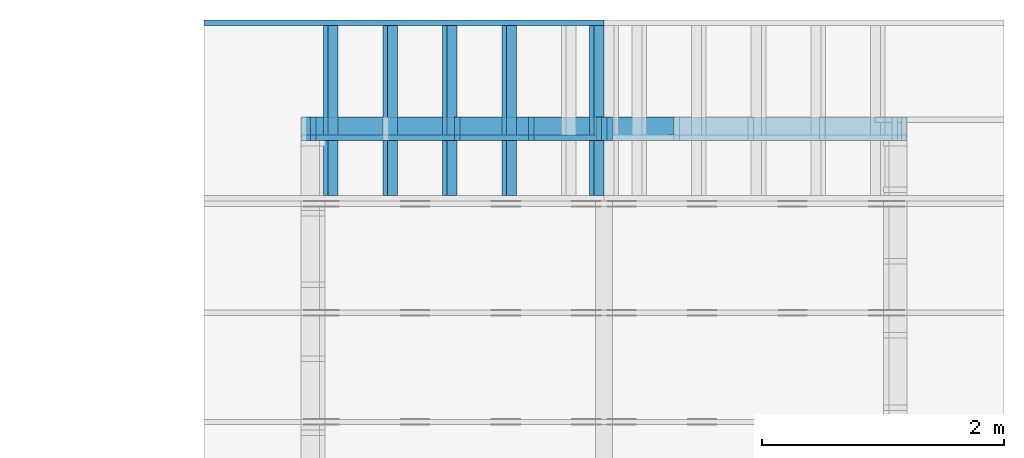
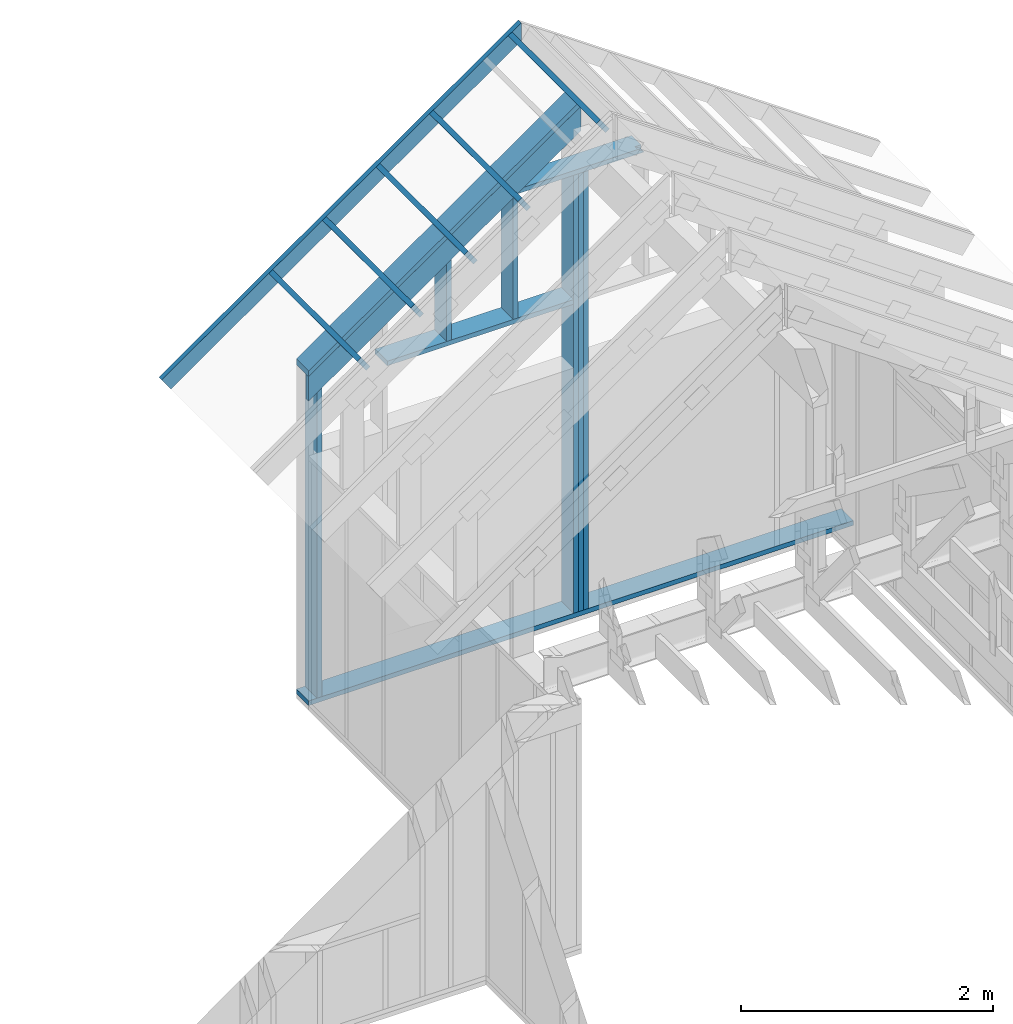
# One storey, part 34 of 70: 17 members, 2 elements without a shape of their own.
"""IFC2X3 building model written with IfcOpenShell, lengths in millimetres."""

from ifc_helpers import new_model, si_unit, frame, origin, origin_with_axes, origin_2d, place, context, project, spatial, faceted_brep, element, aggregate, save


model = new_model("IFC2X3")

# Units and contexts
model_context = context("Model", 3, precision=1e-05, world=origin())
plan_context = context("Plan", 2, precision=1e-05, world=origin_2d())
ifc_project = project(units=[si_unit("LENGTHUNIT", "METRE", prefix="MILLI"), si_unit("AREAUNIT", "SQUARE_METRE"), si_unit("VOLUMEUNIT", "CUBIC_METRE"), si_unit("SOLIDANGLEUNIT", "STERADIAN"), si_unit("PLANEANGLEUNIT", "RADIAN"), si_unit("MASSUNIT", "GRAM"), si_unit("TIMEUNIT", "SECOND"), si_unit("THERMODYNAMICTEMPERATUREUNIT", "DEGREE_CELSIUS"), si_unit("LUMINOUSINTENSITYUNIT", "LUMEN")], contexts=[model_context, plan_context])

# Site, building, storey
site_placement = place(None, origin_with_axes())
site = spatial("IfcSite", under=ifc_project, at=site_placement, CompositionType="ELEMENT")
building_placement = place(site_placement, origin_with_axes())
building = spatial("IfcBuilding", under=site, at=building_placement, Name="Layout 1", CompositionType="ELEMENT")
storey_placement = place(building_placement, origin_with_axes())
storey = spatial("IfcBuildingStorey", under=building, at=storey_placement, Name="Storey 1", CompositionType="ELEMENT", Elevation=0.0)

# Assembly, members
assembly_1_placement = place(storey_placement, frame((12000.0, 12000.0, -2470.0), z_axis=(1.2246063538223773e-16, 1.0, 6.123031769111886e-17), x_axis=(-1.0, 1.2246063538223773e-16, 0.0)))
assembly_1 = element("IfcElementAssembly", 1, at=assembly_1_placement, inside=storey, Name="VE6", AssemblyPlace="FACTORY", PredefinedType="NOTDEFINED")
member_1_placement = place(assembly_1_placement, frame((2474.1890603637416, 5006.644688160831, -195.0), z_axis=(0.0, 0.0, 1.0), x_axis=(0.819152044288991, -0.5735764363510472, 0.0)))
member_1 = element("IfcMember", 2, at=member_1_placement, Name="P9", context=model_context, shape_type="Brep", body=[
    faceted_brep([(3051.936471903848, 45.000000000511136, 195.0), (0.0, 45.000000000511136, 195.0), (31.50933921872638, 1.8226273823529482e-09, 195.0), (3083.4458111236427, 1.8226273823529482e-09, 195.0), (0.0, 45.000000000511136, 0.0), (3051.936471903848, 45.000000000511136, 3.7374207949557014e-13), (3083.4458111236427, 1.8226273823529482e-09, 3.776007331969007e-13), (31.50933921872638, 1.8226273823529482e-09, 3.858653701199695e-15), (31.50933921872638, 1.8226327114234664e-09, -1.9721522630525295e-31), (31.509339218726396, 1.822639816850824e-09, 195.0), (0.0, 45.00000000080673, 195.0), (-1.0658141036401503e-14, 45.00000000080672, 7.888609052210118e-31), (3083.4458111236427, 5.056527393017496e-13, -3.096127786882771e-29), (3083.4458111236427, 5.175926512515177e-13, 195.0), (31.50933921872638, 1.8226444894657068e-09, 195.0), (31.50933921872638, 1.822632549553757e-09, -3.1638934709611835e-31), (3051.936471903848, 45.00000000051091, 5.605193857299268e-45), (3051.936471903848, 45.00000000051091, 195.0), (3083.4458111236427, -2.2737367544323206e-13, 195.0), (3083.4458111236427, -2.2737367544323206e-13, 5.605193857299268e-45), (0.0, 45.00000000080672, 0.0), (-8.077935669463161e-28, 45.00000000080671, 195.0), (3051.936471903848, 45.00000000051174, 195.0), (3051.936471903848, 45.00000000051175, 3.747089299799806e-29)], [[[0, 1, 2, 3]], [[4, 5, 6, 7]], [[8, 9, 10, 11]], [[12, 13, 14, 15]], [[16, 17, 18, 19]], [[20, 21, 22, 23]]]),
])
member_2_placement = place(assembly_1_placement, frame((4999.999999999999, 90.0, -195.0), z_axis=(0.0, 0.0, 1.0), x_axis=(-1.0, 1.2246063538223773e-16, 0.0)))
member_2 = element("IfcMember", 3, at=member_2_placement, Name="P5", context=model_context, shape_type="Brep", body=[
    faceted_brep([(4999.999999999999, 45.00000000000061, 195.0), (0.0, 45.00000000000061, 195.0), (0.0, 0.0, 195.0), (4999.999999999999, 0.0, 195.0), (0.0, 45.00000000000061, 0.0), (4999.999999999999, 45.00000000000061, 6.123031769111885e-13), (4999.999999999999, 0.0, 6.123031769111885e-13), (0.0, 0.0, 0.0), (0.0, 0.0, 0.0), (1.1939911949768178e-14, -1.462169203776584e-30, 195.0), (1.7450640541968876e-14, 45.0, 195.0), (5.510728592200698e-15, 45.0, -3.3742366240998092e-31), (4999.999999999999, -9.184547653667827e-13, 9.365308846991873e-29), (4999.999999999999, -9.065148534170146e-13, 195.0), (2.193253805664876e-30, 1.1939911949768178e-14, 195.0), (0.0, 0.0, 0.0), (4999.999999999999, 45.00000000000061, 0.0), (4999.999999999999, 45.00000000000061, 195.0), (4999.999999999999, 6.110667527536862e-13, 195.0), (4999.999999999999, 6.110667527536862e-13, 0.0), (0.0, 45.0, 0.0), (1.5777218104420236e-30, 44.999999999999986, 195.0), (4999.999999999999, 45.00000000000079, 195.0), (4999.999999999999, 45.0000000000008, 1.1832913578315177e-29)], [[[0, 1, 2, 3]], [[4, 5, 6, 7]], [[8, 9, 10, 11]], [[12, 13, 14, 15]], [[16, 17, 18, 19]], [[20, 21, 22, 23]]]),
])
member_3_placement = place(assembly_1_placement, frame((4922.4999999994125, 90.0, -195.00000000000003), z_axis=(0.0, 0.0, 1.0), x_axis=(6.123031769111886e-17, 1.0, 0.0)))
member_3 = element("IfcMember", 4, at=member_3_placement, Name="S4/", context=model_context, shape_type="Brep", body=[
    faceted_brep([(2995.777206757778, 45.00000000000978, 2.8421709430404083e-14), (2995.777206757778, 45.00000000000978, 45.00000000000003), (2964.267867538344, -2.2737367544323206e-13, 45.00000000000003), (2964.267867538344, -2.2737367544323206e-13, 2.8421709430404083e-14), (2995.7772067577775, 45.000000000010004, 45.0000000000004), (3233.828251566185, 45.000000000010004, 45.000000000000426), (3202.318912346716, 2.3646862246096134e-11, 45.00000000000042), (2964.26786753831, 2.3646862246096134e-11, 45.00000000000039), (4.547473508864641e-13, 45.000000000009095, 2.842170943040401e-14), (4.547473508864641e-13, 45.00000000000908, 195.00000000000003), (3233.828251566185, 45.00000000000888, 195.00000000000003), (3233.828251566185, 45.000000000008896, 45.00000000000003), (2995.7772067577775, 45.00000000000891, 45.00000000000003), (2995.7772067577775, 45.00000000000891, 2.8421709430403995e-14), (4.547473508864641e-13, 45.00000000002365, 2.8421709430404064e-14), (2995.7772067577775, 45.00000000002365, 3.952864896335868e-13), (2964.2678675383095, 2.3646862246096134e-11, 3.914278359322963e-13), (0.0, 2.3646862246096134e-11, 2.842170943040401e-14), (-5.038518148775102e-27, 2.3646862246096134e-11, 3.0851006694196666e-43), (1.193991194976314e-14, 2.3646862246096134e-11, 195.00000000000003), (4.570989582935258e-13, 45.00000000002365, 195.00000000000003), (4.4515904634375764e-13, 45.00000000002365, 5.870949332691174e-31), (3202.318912346716, 2.306138059733843e-11, 45.00000000000003), (3202.318912346716, 2.30705651449921e-11, 195.00000000000003), (2.1932538056648764e-30, 2.3658802158045902e-11, 195.00000000000003), (3.196719095986404e-46, 2.3646862246096134e-11, 2.8421709430404004e-14), (2964.26786753831, 2.3102353056343295e-11, 2.8421709430404045e-14), (2964.26786753831, 2.3105108420639396e-11, 45.00000000000003), (3233.828251566151, 45.0000000000332, 45.00000000000003), (3233.828251566151, 45.0000000000332, 195.00000000000003), (3202.318912346717, 2.319211489520967e-11, 195.00000000000003), (3202.318912346717, 2.319211489520967e-11, 45.00000000000003), (3233.828251566185, 45.000000000009095, 195.00000000000003), (4.547473508864641e-13, 45.000000000009095, 195.00000000000003), (0.0, 2.3646862246096134e-11, 195.00000000000003), (3202.318912346716, 2.3646862246096134e-11, 195.00000000000003)], [[[0, 1, 2, 3]], [[4, 5, 6, 7]], [[8, 9, 10, 11, 12, 13]], [[14, 15, 16, 17]], [[18, 19, 20, 21]], [[22, 23, 24, 25, 26, 27]], [[28, 29, 30, 31]], [[32, 33, 34, 35]]]),
])
member_4_placement = place(assembly_1_placement, frame((2567.499999999389, 90.0, -195.0), z_axis=(0.0, 0.0, 1.0), x_axis=(6.123031769111886e-17, 1.0, 0.0)))
member_4 = element("IfcMember", 5, at=member_4_placement, Name="S1", context=model_context, shape_type="Brep", body=[
    faceted_brep([(4249.700815737255, 45.000000000000455, 195.0), (0.0, 45.000000000000455, 195.0), (0.0, 0.0, 195.0), (4249.700815737255, 0.0, 195.0), (0.0, 45.000000000000455, 0.0), (4249.700815737255, 45.000000000000455, 5.204210620795982e-13), (4249.700815737255, 0.0, 5.204210620795982e-13), (0.0, 0.0, 0.0), (0.0, 0.0, 0.0), (1.1939911949768178e-14, -1.462169203776584e-30, 195.0), (1.7450640541968876e-14, 45.0, 195.0), (5.510728592200698e-15, 45.0, -3.3742366240998092e-31), (4249.700815737255, 1.8091831180479842e-11, -1.88905853583765e-28), (4249.700815737255, 1.810377109242961e-11, 195.0), (-5.083060682885383e-29, 1.1939911949768178e-14, 195.0), (0.0, 0.0, 0.0), (4249.700815737255, 45.000000000000455, 0.0), (4249.700815737255, 45.000000000000455, 195.0), (4249.700815737255, 1.5006662579253316e-11, 195.0), (4249.700815737255, 1.5006662579253316e-11, 0.0), (0.0, 45.0, 0.0), (1.5777218104420236e-30, 44.999999999999986, 195.0), (4249.700815737255, 45.000000000000675, 195.0), (4249.700815737255, 45.00000000000068, 1.3805065841367707e-29)], [[[0, 1, 2, 3]], [[4, 5, 6, 7]], [[8, 9, 10, 11]], [[12, 13, 14, 15]], [[16, 17, 18, 19]], [[20, 21, 22, 23]]]),
])
member_5_placement = place(assembly_1_placement, frame((2522.499999999389, 90.0, -195.0), z_axis=(0.0, 0.0, 1.0), x_axis=(6.123031769111886e-17, 1.0, 0.0)))
member_5 = element("IfcMember", 6, at=member_5_placement, Name="S1", context=model_context, shape_type="Brep", body=[
    faceted_brep([(4249.700815737255, 45.00000000001501, 195.0), (0.0, 45.00000000001501, 195.0), (0.0, 0.0, 195.0), (4249.700815737255, 0.0, 195.0), (0.0, 45.00000000001501, 0.0), (4249.700815737255, 45.00000000001501, 5.204210620795982e-13), (4249.700815737255, 0.0, 5.204210620795982e-13), (0.0, 0.0, 0.0), (0.0, 0.0, 0.0), (1.1939911949768178e-14, -1.462169203776584e-30, 195.0), (1.745064054197066e-14, 45.00000000001455, 195.0), (5.51072859220248e-15, 45.00000000001455, -3.3742366241009005e-31), (4249.700815737255, -7.806315931193973e-13, 7.564264521039784e-29), (4249.700815737255, -7.686916811696291e-13, 195.0), (2.193253805664876e-30, 1.1939911949768178e-14, 195.0), (0.0, 0.0, 0.0), (4249.700815737255, 45.00000000001501, 0.0), (4249.700815737255, 45.00000000001501, 195.0), (4249.700815737255, 4.547473508864641e-13, 195.0), (4249.700815737255, 4.547473508864641e-13, 0.0), (0.0, 45.00000000001455, 0.0), (1.5777218104420236e-30, 45.00000000001454, 195.0), (4249.700815737255, 45.00000000001523, 195.0), (4249.700815737255, 45.000000000015234, 1.3805065841367707e-29)], [[[0, 1, 2, 3]], [[4, 5, 6, 7]], [[8, 9, 10, 11]], [[12, 13, 14, 15]], [[16, 17, 18, 19]], [[20, 21, 22, 23]]]),
])
member_6_placement = place(assembly_1_placement, frame((2477.4999999993743, 89.99999999999999, -195.0), z_axis=(0.0, 0.0, 1.0), x_axis=(6.123031769111886e-17, 1.0, 0.0)))
member_6 = element("IfcMember", 7, at=member_6_placement, Name="S1", context=model_context, shape_type="Brep", body=[
    faceted_brep([(4249.700815737255, 45.000000000000455, 195.0), (0.0, 45.000000000000455, 195.0), (1.4210854715202004e-14, 0.0, 195.0), (4249.700815737255, 0.0, 195.0), (0.0, 45.000000000000455, 0.0), (4249.700815737255, 45.000000000000455, 5.204210620795982e-13), (4249.700815737255, 0.0, 5.204210620795982e-13), (1.4210854715202004e-14, 0.0, 1.7402702977483063e-30), (1.4210854715202002e-14, 0.0, 1.7516230804060213e-46), (2.6150766664970182e-14, -1.462169203776584e-30, 195.0), (3.166149525717088e-14, 45.0, 195.0), (1.97215833074027e-14, 45.0, -1.2075588112841339e-30), (4249.700815737255, -7.806315931193973e-13, 7.564264521039784e-29), (4249.700815737255, -7.686916811696291e-13, 195.0), (1.4210854715202007e-14, 1.1939911949768174e-14, 195.0), (1.4210854715202004e-14, -4.131065092035501e-30, 2.5294642798802494e-46), (4249.700815737255, 45.000000000000455, 0.0), (4249.700815737255, 45.000000000000455, 195.0), (4249.700815737255, 4.547473508864641e-13, 195.0), (4249.700815737255, 4.547473508864641e-13, 0.0), (0.0, 45.0, 0.0), (1.5777218104420236e-30, 44.999999999999986, 195.0), (4249.700815737255, 45.000000000000675, 195.0), (4249.700815737255, 45.00000000000068, 1.3805065841367707e-29)], [[[0, 1, 2, 3]], [[4, 5, 6, 7]], [[8, 9, 10, 11]], [[12, 13, 14, 15]], [[16, 17, 18, 19]], [[20, 21, 22, 23]]]),
])
member_7_placement = place(assembly_1_placement, frame((3687.5000000011987, 4157.075222035528, -195.0), z_axis=(0.0, 0.0, 1.0), x_axis=(-1.836909530733566e-16, -1.0, 0.0)))
member_7 = element("IfcMember", 8, at=member_7_placement, Name="S29/", context=model_context, shape_type="Brep", body=[
    faceted_brep([(31.509339219475805, 45.00000000002365, 45.00000000000001), (269.56038402787544, 45.00000000002365, 45.000000000000036), (238.05104480840146, 2.3646862246096134e-11, 45.00000000000003), (0.0, 2.3646862246096134e-11, 45.0), (238.05104480843508, -1.4210854715202004e-14, 1.5777218104420236e-30), (238.05104480843508, -1.4210854715202004e-14, 45.0), (269.56038402787544, 45.00000000002001, 45.0), (269.56038402787544, 45.00000000002001, 1.5777218104420236e-30), (3.274269947936954e-11, 9.08871366138303e-13, 45.0), (3.2750223020355916e-11, 9.036033260256165e-13, 195.0), (31.509339219475805, 45.000000000023654, 195.0), (31.509339219475798, 45.00000000002366, 45.0), (1022.0752220355334, 2.3459116274447763e-11, 3.9340070253230344e-29), (1022.0752220355334, 2.347105618639753e-11, 195.0), (2.193253805664876e-30, 2.3658802158045902e-11, 195.0), (5.061354936149714e-31, 2.3649617610392235e-11, 45.0), (238.05104480840146, 2.360588978709127e-11, 45.0), (238.05104480840146, 2.360313442279517e-11, 2.677468512659129e-30), (31.509339219475805, 45.00000000002, 45.0), (31.509339219475805, 45.000000000019995, 195.0), (1022.0752220355325, 45.00000000001994, 195.0), (1022.0752220355325, 45.000000000019945, -3.194886666145098e-29), (269.56038402787544, 45.000000000019995, -1.1832913578315177e-30), (269.56038402787544, 45.00000000001999, 45.0), (1022.0752220355334, 45.00000000000955, 2.842170943040407e-14), (1022.0752220355334, 45.00000000000955, 195.0), (1022.0752220355334, 2.4101609596982598e-11, 195.0), (1022.0752220355334, 2.4101609596982598e-11, 0.0), (1022.0752220355325, 45.00000000000955, 195.0), (31.509339219475805, 45.00000000000955, 195.0), (0.0, 2.3646862246096134e-11, 195.0), (1022.0752220355334, 2.3646862246096134e-11, 195.0), (269.56038402787544, 45.00000000002001, 3.3010535901933635e-14), (1022.0752220355325, 45.00000000002001, 1.25163981098913e-13), (1022.0752220355334, 2.4101609596982598e-11, 1.2516398109891314e-13), (238.05104480840146, 2.4101609596982598e-11, 2.915188220064239e-14)], [[[0, 1, 2, 3]], [[4, 5, 6, 7]], [[8, 9, 10, 11]], [[12, 13, 14, 15, 16, 17]], [[18, 19, 20, 21, 22, 23]], [[24, 25, 26, 27]], [[28, 29, 30, 31]], [[32, 33, 34, 35]]]),
])
member_8_placement = place(assembly_1_placement, frame((4277.499999999389, 3135.0, -195.0), z_axis=(0.0, 0.0, 1.0), x_axis=(-1.0, 1.2246063538223773e-16, 0.0)))
member_8 = element("IfcMember", 9, at=member_8_placement, Name="S18", context=model_context, shape_type="Brep", body=[
    faceted_brep([(1710.000000000011, 45.0, 195.0), (0.0, 45.0, 195.0), (0.0, 0.0, 195.0), (1710.000000000011, 0.0, 195.0), (0.0, 45.0, 0.0), (1710.000000000011, 45.0, 2.0940768650362785e-13), (1710.000000000011, 0.0, 2.0940768650362785e-13), (0.0, 0.0, 0.0), (0.0, 0.0, 0.0), (1.1939911949768178e-14, -1.462169203776584e-30, 195.0), (1.745064054197066e-14, 45.00000000001455, 195.0), (5.51072859220248e-15, 45.00000000001455, -3.3742366241009005e-31), (1710.000000000011, 1.3354954349429573e-11, 7.329029488117048e-29), (1710.000000000011, 1.3366894261379341e-11, 195.0), (-9.32496953364688e-29, 1.1939911949768178e-14, 195.0), (0.0, 0.0, 0.0), (1710.000000000011, 45.0, 0.0), (1710.000000000011, 45.0, 195.0), (1710.000000000011, 1.4551915228366852e-11, 195.0), (1710.000000000011, 1.4551915228366852e-11, 0.0), (0.0, 45.00000000001455, 0.0), (-1.0097419586828951e-28, 45.00000000001454, 195.0), (1710.000000000011, 45.00000000000001, 195.0), (1710.000000000011, 45.00000000000002, 1.1832913578315177e-30)], [[[0, 1, 2, 3]], [[4, 5, 6, 7]], [[8, 9, 10, 11]], [[12, 13, 14, 15]], [[16, 17, 18, 19]], [[20, 21, 22, 23]]]),
])
member_9_placement = place(assembly_1_placement, frame((3122.4999999994034, 3134.9999999999986, -195.0), z_axis=(0.0, 0.0, 1.0), x_axis=(6.123031769111886e-17, 1.0, 0.0)))
member_9 = element("IfcMember", 10, at=member_9_placement, Name="S19", context=model_context, shape_type="Brep", body=[
    faceted_brep([(1211.150775538174, 45.00000000187583, -1.262177448353619e-29), (1211.150775538174, 45.00000000187583, 45.0), (1179.6414363187228, 1.8417267710901797e-09, 45.0), (1179.6414363187228, 1.8417267710901797e-09, 0.0), (1211.150775538174, 45.00000000187583, 45.00000000000015), (1449.201820346841, 45.00000000187583, 45.00000000000018), (1417.6924811273652, 1.8649188859853894e-09, 45.00000000000017), (1179.641436318689, 1.8649188859853894e-09, 45.00000000000014), (2.800456213534592e-29, 45.00000000224145, 2.800456213534592e-29), (2.7273477533457627e-29, 45.000000002241435, 195.0), (1449.201820346841, 45.00000000224135, 195.0), (1449.201820346841, 45.00000000224136, 45.0), (1211.150775538174, 45.00000000224137, 45.0), (1211.150775538174, 45.00000000224138, -4.733165431326071e-30), (0.0, 45.00000000001455, 0.0), (1211.150775538174, 45.00000000001455, 1.4831829351609478e-13), (1179.641436318689, 1.865373633336276e-09, 1.4445963981480218e-13), (1.3642420526593924e-12, 1.865373633336276e-09, 1.670659485838374e-28), (1.3642420526593924e-12, 0.0, 0.0), (1.3761819646091605e-12, 3.5910008311095063e-28, 195.0), (2.2779711059732005e-14, 45.00000000001455, 195.0), (1.0839799109963827e-14, 45.00000000001455, -6.637243432109955e-31), (1417.6924811273652, 1.8646612240666624e-09, 45.0), (1417.6924811273652, 1.864670408614316e-09, 195.0), (1.3642420526593924e-12, 1.864930825897339e-09, 195.0), (1.3642420526593924e-12, 1.8649188859853894e-09, -2.78443247639729e-29), (1179.641436318689, 1.864702196525667e-09, 1.3267964459105144e-29), (1179.641436318689, 1.8647049518899633e-09, 45.0), (1449.2018203468665, 45.00000000222337, 45.0), (1449.2018203468665, 45.00000000222337, 195.0), (1417.6924811273652, 2.2414496925193816e-09, 195.0), (1417.6924811273652, 2.2414496925193816e-09, 45.0), (1449.201820346841, 45.00000000224145, 195.0), (0.0, 45.00000000224145, 195.0), (1.3642420526593924e-12, 0.0, 195.0), (1417.6924811273652, 0.0, 195.0)], [[[0, 1, 2, 3]], [[4, 5, 6, 7]], [[8, 9, 10, 11, 12, 13]], [[14, 15, 16, 17]], [[18, 19, 20, 21]], [[22, 23, 24, 25, 26, 27]], [[28, 29, 30, 31]], [[32, 33, 34, 35]]]),
])
member_10_placement = place(assembly_1_placement, frame((1922.500000000001, 4339.700815717399, -195.0), z_axis=(0.0, 0.0, 1.0), x_axis=(1.0, 2.362323900716526e-15, 0.0)))
member_10 = element("IfcMember", 11, at=member_10_placement, Name="S27", context=model_context, shape_type="Brep", body=[
    faceted_brep([(1099.9448369288095, 45.000000018900266, 0.0), (1099.9448369288095, 45.000000018900266, 45.0), (1154.9999999962727, 6.44995982164528, 45.0), (1154.9999999962727, 6.44995982164528, 0.0), (2.2737367544323206e-13, 45.00000001890021, 45.0), (55.055163047768474, 45.00000001890021, 45.00000000000001), (0.0, 6.449959821647099, 45.0), (1099.9448369288095, 45.00000001890021, 45.000000000000135), (1154.999999996274, 45.00000001890021, 45.00000000000014), (1154.999999996274, 6.449959821647099, 45.00000000000014), (2.2737367544323206e-13, 45.000000019846084, 45.0), (2.2737367544323206e-13, 45.00000001984607, 195.0), (1154.999999996274, 45.000000019846, 195.0), (1154.999999996274, 45.00000001984601, 45.0), (1099.9448369288095, 45.00000001984601, 45.0), (1099.9448369288095, 45.00000001984602, -3.944304526105059e-30), (55.055163047768474, 45.000000019846084, -3.944304526105059e-31), (55.055163047768474, 45.00000001984608, 45.0), (55.055163047768474, 45.000000000945874, 6.742090247902423e-15), (1099.9448369288095, 45.000000000945874, 1.3469994361571388e-13), (1154.999999996274, 6.449959821647099, 1.414420338660283e-13), (1154.999999996274, 1.9846083887387067e-08, 1.414420338660283e-13), (0.0, 1.9846083887387067e-08, 0.0), (0.0, 6.449959821647099, 0.0), (6.830092047493963e-13, 6.449959817526176, -9.860761315262648e-32), (6.847855615887966e-13, 6.4499598175261745, 45.0), (55.05516304776848, 45.000000000945874, 45.0), (55.05516304776848, 45.000000000945874, -6.409494854920721e-31), (-3.804278966326658e-14, 2.2428584542055484e-28, 2.3293720969382256e-30), (-2.61028777134984e-14, 1.5389265739190394e-28, 195.00000000000003), (2.3920003864098893e-13, 45.0, 195.00000000000003), (2.300154909873211e-13, 45.0, 45.0), (2.7390890763714002e-15, 6.449959817527088, 45.0), (-1.627521972894859e-17, 6.449959817527088, 9.965368744964731e-34), (1154.999999996274, 1.9845871724336267e-08, 1.2990811002784266e-29), (1154.999999996274, 1.9845883664248217e-08, 195.0), (2.193253805664876e-30, 1.9846095827299017e-08, 195.0), (0.0, 1.9846083887387067e-08, 0.0), (1154.999999996274, 45.000000019846084, 45.0), (1154.999999996274, 45.000000019846084, 195.0), (1154.999999996274, 1.9846083887387067e-08, 195.0), (1154.999999996274, 1.9846083887387067e-08, 0.0), (1154.999999996274, 6.449959821647099, 0.0), (1154.999999996274, 6.449959821647099, 45.0), (1154.999999996274, 45.000000019846084, 195.0), (2.2737367544323206e-13, 45.000000019846084, 195.0), (0.0, 0.0, 195.0), (1154.999999996274, 0.0, 195.0)], [[[0, 1, 2, 3]], [[4, 5, 6]], [[7, 8, 9]], [[10, 11, 12, 13, 14, 15, 16, 17]], [[18, 19, 20, 21, 22, 23]], [[24, 25, 26, 27]], [[28, 29, 30, 31, 32, 33]], [[34, 35, 36, 37]], [[38, 39, 40, 41, 42, 43]], [[44, 45, 46, 47]]]),
])
member_11_placement = place(assembly_1_placement, frame((2388.1525949127777, 4828.837025024257, -195.0), z_axis=(0.0, 0.0, 1.0), x_axis=(0.8191520442886487, -0.5735764363515361, 0.0)))
member_11 = element("IfcMember", 12, at=member_11_placement, Name="L6", context=model_context, shape_type="Brep", body=[
    faceted_brep([(3051.9364719044206, 195.00000000000455, 45.0), (0.0, 195.00000000000455, 45.0), (136.54046995055774, 6.330083124339581e-10, 45.0), (3188.476941855407, 6.330083124339581e-10, 45.0), (0.0, 195.00000000000455, 0.0), (3051.9364719044206, 195.00000000000455, 3.7374207949564026e-13), (3188.476941855407, 6.330083124339581e-10, 3.904629122012274e-13), (136.54046995055774, 6.330083124339581e-10, 1.6720832705534637e-14), (136.5404699505577, 6.330083124339581e-10, 1.5777218104420236e-30), (136.5404699505577, 6.330083124339581e-10, 45.0), (-1.4210854715202004e-14, 194.99999999999542, 45.0), (-1.4210854715202004e-14, 194.99999999999542, 7.888609052210118e-31), (3188.476941855407, 9.015690517294836e-13, -5.520335945787904e-29), (3188.476941855407, 9.04324416025584e-13, 45.0), (136.54046995055774, 6.330496757807677e-10, 45.0), (136.54046995055774, 6.330469204164716e-10, -2.3639790347175294e-30), (3051.936471904421, 195.000000000005, 5.048709793414476e-29), (3051.936471904421, 195.000000000005, 45.0), (3188.4769418554074, 4.547473508864641e-13, 45.0), (3188.4769418554074, 4.547473508864641e-13, 5.048709793414476e-29), (0.0, 194.99999999999545, 0.0), (0.0, 194.99999999999545, 45.0), (3051.9364719044206, 195.00000000000543, 45.0), (3051.9364719044206, 195.00000000000543, 5.522026336547083e-29)], [[[0, 1, 2, 3]], [[4, 5, 6, 7]], [[8, 9, 10, 11]], [[12, 13, 14, 15]], [[16, 17, 18, 19]], [[20, 21, 22, 23]]]),
])
aggregate(assembly_1, [member_1, member_2, member_3, member_4, member_5, member_6, member_7, member_8, member_9, member_10, member_11])

assembly_2_placement = place(storey_placement, frame((9499.999999999996, 12800.0, 2750.5188455242724), z_axis=(-0.5735764363510464, 8.131391261780321e-17, 0.8191520442889916), x_axis=(-0.8191520442889916, 1.3543414723620324e-16, -0.5735764363510464)))
assembly_2 = element("IfcElementAssembly", 13, at=assembly_2_placement, inside=storey, Name="gs4", AssemblyPlace="FACTORY", PredefinedType="TRUSS")
member_12_placement = place(assembly_2_placement, frame((4028.55614291328, 45.0, -145.00000000000003), z_axis=(0.0, 0.0, 1.0), x_axis=(-1.0, 1.2246063538223773e-16, 0.0)))
member_12 = element("IfcMember", 14, at=member_12_placement, Name="T4", context=model_context, shape_type="Brep", body=[
    faceted_brep([(3927.0260498725515, 45.00000000000049, -2.2737367544323206e-13), (4028.55614291328, 45.00000000000049, 145.00000000000045), (4028.55614291328, 4.902744876744707e-13, 145.00000000000045), (3927.0260498725515, 4.902744876744707e-13, -2.2737367544323206e-13), (4.547473508864641e-13, 45.00000000000049, 2.842170943040401e-14), (4.547473508864641e-13, 45.00000000000048, 145.00000000000003), (4028.55614291328, 45.000000000000234, 145.00000000000003), (3927.0260498725515, 45.00000000000025, 2.8421709430403995e-14), (4.547473508864641e-13, 45.0, 2.8421709430404064e-14), (3927.0260498725515, 45.0, 5.093278146603959e-13), (3927.0260498725515, 4.760636329592671e-13, 5.093278146603959e-13), (0.0, 4.760636329592671e-13, 2.842170943040401e-14), (3.4805405954966126e-30, -3.4430980716711644e-44, 5.684341886080802e-14), (8.878396065212237e-15, -8.782885167671322e-29, 145.00000000000003), (4.5403744240897487e-13, 44.99999999999999, 145.00000000000003), (4.4515904634376264e-13, 44.99999999999999, 2.842170943040401e-14), (4028.5561429132795, -2.479618610191853e-13, 145.00000000000003), (1.6308810349815748e-30, 4.920474563820804e-13, 145.00000000000003), (3.503246160812043e-46, 4.831690603168681e-13, 2.842170943040401e-14), (3927.0260498725515, -2.3819009752811965e-13, 2.842170943040405e-14), (4028.55614291328, 45.00000000000049, 145.00000000000003), (4.547473508864641e-13, 45.00000000000049, 145.00000000000003), (0.0, 0.0, 145.00000000000003), (4028.5561429132795, 0.0, 145.00000000000003)], [[[0, 1, 2, 3]], [[4, 5, 6, 7]], [[8, 9, 10, 11]], [[12, 13, 14, 15]], [[16, 17, 18, 19]], [[20, 21, 22, 23]]]),
])
member_13_placement = place(assembly_2_placement, frame((146.53009303979334, 45.0, -145.0), z_axis=(0.0, 0.0, 1.0), x_axis=(6.123031769111886e-17, 1.0, 0.0)))
member_13 = element("IfcMember", 15, at=member_13_placement, Name="W2", context=model_context, shape_type="Brep", body=[
    faceted_brep([(1404.9999999999982, 45.0, 145.0), (0.0, 45.0, 145.0), (0.0, 1.446665010007564e-11, 145.0), (1404.9999999999982, 1.446665010007564e-11, 145.0), (0.0, 45.0, 0.0), (1404.9999999999982, 45.0, 1.7205719271204378e-13), (1404.9999999999982, 1.446665010007564e-11, 1.7205719271204378e-13), (0.0, 1.446665010007564e-11, 0.0), (1.771595163107776e-27, 1.446665010007564e-11, -1.0847533465713865e-43), (8.878396065214007e-15, 1.446665010007564e-11, 145.0), (1.4389124657414706e-14, 45.00000000001447, 145.0), (5.5107285922024694e-15, 45.00000000001447, -3.374236624100894e-31), (1404.9999999999982, 4.817668345421561e-13, -2.94987363320609e-29), (1404.9999999999982, 4.906452306073683e-13, 145.0), (8.837247868837372e-29, 1.4475528496140852e-11, 145.0), (0.0, 1.446665010007564e-11, 0.0), (1404.9999999999982, 45.0, 0.0), (1404.9999999999982, 45.0, 145.0), (1404.9999999999982, 0.0, 145.0), (1404.9999999999982, 0.0, 0.0), (0.0, 45.00000000001447, 0.0), (-1.0097419586828951e-28, 45.00000000001446, 145.0), (1404.9999999999982, 45.00000000000002, 145.0), (1404.9999999999982, 45.00000000000003, 1.9721522630525295e-30)], [[[0, 1, 2, 3]], [[4, 5, 6, 7]], [[8, 9, 10, 11]], [[12, 13, 14, 15]], [[16, 17, 18, 19]], [[20, 21, 22, 23]]]),
])
member_14_placement = place(assembly_2_placement, frame((2783.556142915099, 1449.9999999999982, -145.0), z_axis=(0.0, 0.0, 1.0), x_axis=(-1.836909530733566e-16, -1.0, 0.0)))
member_14 = element("IfcMember", 16, at=member_14_placement, Name="W2", context=model_context, shape_type="Brep", body=[
    faceted_brep([(1404.9999999999982, 45.00000000001455, 145.0), (0.0, 45.00000000001455, 145.0), (0.0, 1.4097167877480388e-11, 145.0), (1404.9999999999982, 1.4097167877480388e-11, 145.0), (0.0, 45.00000000001455, 0.0), (1404.9999999999982, 45.00000000001455, 1.7205719271204378e-13), (1404.9999999999982, 1.4097167877480388e-11, 1.7205719271204378e-13), (0.0, 1.4097167877480388e-11, 0.0), (1.72634813536632e-27, 1.4097167877480388e-11, -1.0570484477395044e-43), (8.878396065213961e-15, 1.4097167877480388e-11, 145.0), (1.4389124657416442e-14, 45.00000000002865, 145.0), (5.510728592204206e-15, 45.00000000002865, -3.3742366241019576e-31), (1404.9999999999982, 1.1228461194690399e-13, -6.87522246133292e-30), (1404.9999999999982, 1.2116300801211622e-13, 145.0), (8.837247868837372e-29, 1.41060462735456e-11, 145.0), (0.0, 1.4097167877480388e-11, 0.0), (1404.9999999999982, 45.00000000001455, 0.0), (1404.9999999999982, 45.00000000001455, 145.0), (1404.9999999999982, 0.0, 145.0), (1404.9999999999982, 0.0, 0.0), (0.0, 45.00000000002865, 0.0), (-1.0097419586828951e-28, 45.00000000002864, 145.0), (1404.9999999999982, 45.000000000014516, 145.0), (1404.9999999999982, 45.00000000001452, -1.9721522630525295e-30)], [[[0, 1, 2, 3]], [[4, 5, 6, 7]], [[8, 9, 10, 11]], [[12, 13, 14, 15]], [[16, 17, 18, 19]], [[20, 21, 22, 23]]]),
])
member_15_placement = place(assembly_2_placement, frame((2183.5561429151135, 1449.9999999999982, -145.0), z_axis=(0.0, 0.0, 1.0), x_axis=(-1.836909530733566e-16, -1.0, 0.0)))
member_15 = element("IfcMember", 17, at=member_15_placement, Name="W2", context=model_context, shape_type="Brep", body=[
    faceted_brep([(1404.9999999999982, 44.99999999998545, 145.0), (0.0, 44.99999999998545, 145.0), (0.0, 1.4097167877480388e-11, 145.0), (1404.9999999999982, 1.4097167877480388e-11, 145.0), (0.0, 44.99999999998545, 0.0), (1404.9999999999982, 44.99999999998545, 1.7205719271204378e-13), (1404.9999999999982, 1.4097167877480388e-11, 1.7205719271204378e-13), (0.0, 1.4097167877480388e-11, 0.0), (1.72634813536632e-27, 1.4097167877480388e-11, -1.0570484477395044e-43), (8.878396065213961e-15, 1.4097167877480388e-11, 145.0), (1.438912465741466e-14, 45.0000000000141, 145.0), (5.510728592202424e-15, 45.0000000000141, -3.3742366241008663e-31), (1404.9999999999982, 1.1228461194690399e-13, -6.87522246133292e-30), (1404.9999999999982, 1.2116300801211622e-13, 145.0), (8.837247868837372e-29, 1.41060462735456e-11, 145.0), (0.0, 1.4097167877480388e-11, 0.0), (1404.9999999999982, 44.99999999998545, 0.0), (1404.9999999999982, 44.99999999998545, 145.0), (1404.9999999999982, 0.0, 145.0), (1404.9999999999982, 0.0, 0.0), (0.0, 45.0000000000141, 0.0), (-2.0194839173657902e-28, 45.00000000001409, 145.0), (1404.9999999999982, 44.99999999998561, 145.0), (1404.9999999999982, 44.99999999998562, 1.064962222048366e-29)], [[[0, 1, 2, 3]], [[4, 5, 6, 7]], [[8, 9, 10, 11]], [[12, 13, 14, 15]], [[16, 17, 18, 19]], [[20, 21, 22, 23]]]),
])
member_16_placement = place(assembly_2_placement, frame((1583.556142915113, 1449.9999999999982, -145.0), z_axis=(0.0, 0.0, 1.0), x_axis=(-1.836909530733566e-16, -1.0, 0.0)))
member_16 = element("IfcMember", 18, at=member_16_placement, Name="W2", context=model_context, shape_type="Brep", body=[
    faceted_brep([(1404.9999999999982, 44.999999999985675, 145.0), (0.0, 44.999999999985675, 145.0), (0.0, 0.0, 145.0), (1404.9999999999982, 0.0, 145.0), (0.0, 44.999999999985675, 0.0), (1404.9999999999982, 44.999999999985675, 1.7205719271204378e-13), (1404.9999999999982, 0.0, 1.7205719271204378e-13), (0.0, 0.0, 0.0), (0.0, 0.0, 0.0), (8.878396065212235e-15, -1.0872540233210496e-30, 145.0), (1.4389124657412933e-14, 45.0, 145.0), (5.510728592200698e-15, 45.0, -3.3742366240998092e-31), (1404.9999999999982, -2.5808578906806565e-13, 2.97248372381872e-29), (1404.9999999999982, -2.492073930028534e-13, 145.0), (1.6308810349815745e-30, 8.878396065212235e-15, 145.0), (0.0, 0.0, 0.0), (1404.9999999999982, 44.999999999985675, 0.0), (1404.9999999999982, 44.999999999985675, 145.0), (1404.9999999999982, 2.2737367544323206e-13, 145.0), (1404.9999999999982, 2.2737367544323206e-13, 0.0), (0.0, 45.0, 0.0), (-1.0097419586828951e-28, 44.99999999999999, 145.0), (1404.9999999999982, 44.999999999985555, 145.0), (1404.9999999999982, 44.99999999998556, -6.7053176943786e-30)], [[[0, 1, 2, 3]], [[4, 5, 6, 7]], [[8, 9, 10, 11]], [[12, 13, 14, 15]], [[16, 17, 18, 19]], [[20, 21, 22, 23]]]),
])
member_17_placement = place(assembly_2_placement, frame((983.5561429150987, 1449.9999999999982, -145.0), z_axis=(0.0, 0.0, 1.0), x_axis=(-1.836909530733566e-16, -1.0, 0.0)))
member_17 = element("IfcMember", 19, at=member_17_placement, Name="T14", context=model_context, shape_type="Brep", body=[
    faceted_brep([(1404.9999999999982, 45.0, 145.0), (0.0, 45.0, 145.0), (0.0, 1.432454155292362e-11, 145.0), (1404.9999999999982, 1.432454155292362e-11, 145.0), (0.0, 45.0, 0.0), (1404.9999999999982, 45.0, 1.7205719271204378e-13), (1404.9999999999982, 1.432454155292362e-11, 1.7205719271204378e-13), (0.0, 1.432454155292362e-11, 0.0), (1.7541924601302928e-27, 1.432454155292362e-11, -1.0740976162514319e-43), (8.87839606521399e-15, 1.432454155292362e-11, 145.0), (1.438912465741647e-14, 45.00000000002888, 145.0), (5.510728592204234e-15, 45.00000000002888, -3.3742366241019747e-31), (1404.9999999999982, 3.3965828739013605e-13, -2.079738484331937e-29), (1404.9999999999982, 3.485366834553483e-13, 145.0), (8.837247868837372e-29, 1.4333419948988832e-11, 145.0), (0.0, 1.432454155292362e-11, 0.0), (1404.9999999999982, 45.0, 0.0), (1404.9999999999982, 45.0, 145.0), (1404.9999999999982, 0.0, 145.0), (1404.9999999999982, 0.0, 0.0), (0.0, 45.00000000002888, 0.0), (-2.0194839173657902e-28, 45.00000000002887, 145.0), (1404.9999999999982, 45.00000000000039, 145.0), (1404.9999999999982, 45.0000000000004, 2.4849118514461872e-29)], [[[0, 1, 2, 3]], [[4, 5, 6, 7]], [[8, 9, 10, 11]], [[12, 13, 14, 15]], [[16, 17, 18, 19]], [[20, 21, 22, 23]]]),
])
aggregate(assembly_2, [member_12, member_13, member_14, member_15, member_16, member_17])

save(model, "model.ifc")
